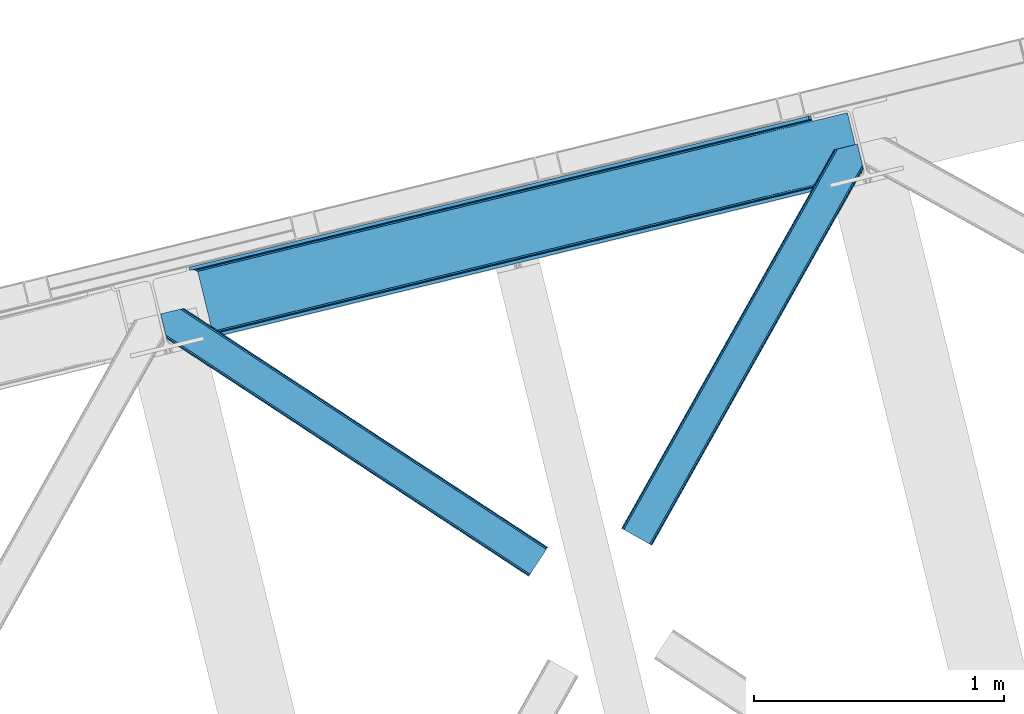
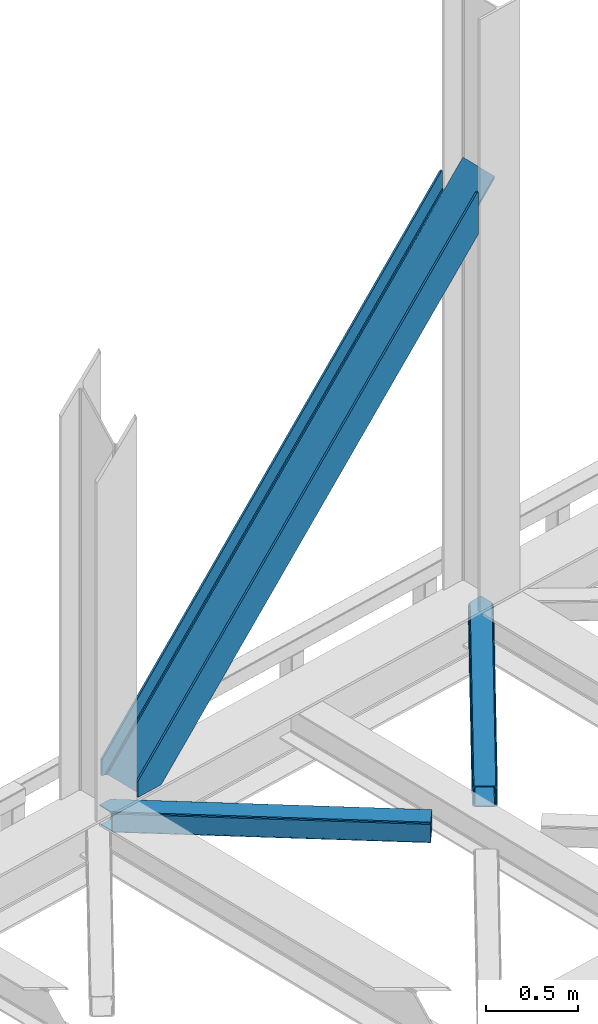
# One storey, part 81 of 92: 3 members.
"""IFC4 building model written with IfcOpenShell, lengths in millimetres."""

from ifc_helpers import new_model, entity, si_unit, converted_unit, derived_unit, direction, frame, origin, place, context, subcontext, project, spatial, triangles, polygons, type_object, element, save


model = new_model("IFC4")

# Units and contexts
model_context = context("Model", 3, precision=0.01, world=origin(), true_north=direction((6.12303176911189e-17, 1.0)))
plan_context = context("Plan", 3, precision=0.01, world=origin(), true_north=direction((6.12303176911189e-17, 1.0)))
body_context = subcontext(model_context, "Body", "Model", "MODEL_VIEW")
ifc_project = project(units=[si_unit("LENGTHUNIT", "METRE", prefix="MILLI"), si_unit("AREAUNIT", "SQUARE_METRE"), si_unit("VOLUMEUNIT", "CUBIC_METRE"), converted_unit("PLANEANGLEUNIT", "DEGREE", entity("IfcRatioMeasure", 0.0174532925199433), si_unit("PLANEANGLEUNIT", "RADIAN"), dimensions=[0, 0, 0, 0, 0, 0, 0]), si_unit("MASSUNIT", "GRAM", prefix="KILO"), derived_unit("MASSDENSITYUNIT", [(si_unit("MASSUNIT", "GRAM", prefix="KILO"), 1), (si_unit("LENGTHUNIT", "METRE"), -3)]), derived_unit("MOMENTOFINERTIAUNIT", [(si_unit("LENGTHUNIT", "METRE"), 4)]), si_unit("TIMEUNIT", "SECOND"), si_unit("FREQUENCYUNIT", "HERTZ"), si_unit("THERMODYNAMICTEMPERATUREUNIT", "DEGREE_CELSIUS"), derived_unit("THERMALTRANSMITTANCEUNIT", [(si_unit("MASSUNIT", "GRAM", prefix="KILO"), 1), (si_unit("THERMODYNAMICTEMPERATUREUNIT", "KELVIN"), -1), (si_unit("TIMEUNIT", "SECOND"), -3)]), derived_unit("VOLUMETRICFLOWRATEUNIT", [(si_unit("LENGTHUNIT", "METRE"), 3), (si_unit("TIMEUNIT", "SECOND"), -1)]), derived_unit("MASSFLOWRATEUNIT", [(si_unit("MASSUNIT", "GRAM", prefix="KILO"), 1), (si_unit("TIMEUNIT", "SECOND"), -1)]), derived_unit("ROTATIONALFREQUENCYUNIT", [(si_unit("TIMEUNIT", "SECOND"), -1)]), si_unit("ELECTRICCURRENTUNIT", "AMPERE"), si_unit("ELECTRICVOLTAGEUNIT", "VOLT"), si_unit("POWERUNIT", "WATT"), si_unit("FORCEUNIT", "NEWTON", prefix="KILO"), si_unit("ILLUMINANCEUNIT", "LUX"), si_unit("LUMINOUSFLUXUNIT", "LUMEN"), si_unit("LUMINOUSINTENSITYUNIT", "CANDELA"), derived_unit("USERDEFINED", [(si_unit("MASSUNIT", "GRAM", prefix="KILO"), -1), (si_unit("LENGTHUNIT", "METRE"), -2), (si_unit("TIMEUNIT", "SECOND"), 3), (si_unit("LUMINOUSFLUXUNIT", "LUMEN"), 1)]), derived_unit("LINEARVELOCITYUNIT", [(si_unit("LENGTHUNIT", "METRE"), 1), (si_unit("TIMEUNIT", "SECOND"), -1)]), si_unit("PRESSUREUNIT", "PASCAL"), derived_unit("USERDEFINED", [(si_unit("LENGTHUNIT", "METRE"), -2), (si_unit("MASSUNIT", "GRAM", prefix="KILO"), 1), (si_unit("TIMEUNIT", "SECOND"), -2)]), derived_unit("LINEARFORCEUNIT", [(si_unit("MASSUNIT", "GRAM", prefix="KILO"), 1), (si_unit("LENGTHUNIT", "METRE"), 1), (si_unit("TIMEUNIT", "SECOND"), -2), (si_unit("LENGTHUNIT", "METRE"), -1)]), derived_unit("PLANARFORCEUNIT", [(si_unit("MASSUNIT", "GRAM", prefix="KILO"), 1), (si_unit("LENGTHUNIT", "METRE"), 1), (si_unit("TIMEUNIT", "SECOND"), -2), (si_unit("LENGTHUNIT", "METRE"), -2)])], contexts=[model_context, plan_context])

# Site, building, storey
site_placement = place(None, origin())
site = spatial("IfcSite", under=ifc_project, at=site_placement, CompositionType="ELEMENT")
building_placement = place(site_placement, origin())
building = spatial("IfcBuilding", under=site, at=building_placement, CompositionType="ELEMENT")
storey_placement = place(building_placement, frame((0.0, 0.0, 15900.0)))
storey = spatial("IfcBuildingStorey", under=building, at=storey_placement, Name="05", CompositionType="ELEMENT", Elevation=15900.0)

# Members
member_type_1 = type_object("IfcMemberType", PredefinedType="BRACE")
member_1_placement = place(storey_placement, frame((-8823.81, 18506.66, 3695.0)))
element("IfcMember", 1, at=member_1_placement, inside=storey, type_object=member_type_1, ObjectType="Steel Vertical Brace", PredefinedType="BRACE", context=body_context, shape_type="Tessellation", body=[
    polygons([(3.07873920987602, 273.977680396013, 8.22979018266778e-11), (3.07873920888086, 273.977680395771, 106.65765827966), (8.66293703438714e-12, 286.607857151607, 106.65765827966), (1.94699509847851e-09, 286.607857152077, 8.22979018266778e-11), (2479.77214765689, 877.697901605217, 2779.57626168554), (2490.25200805125, 880.252478451081, 2781.6827939859), (2487.17326884237, 892.882655206916, 2781.6827939859), (2476.69340844802, 890.328078361052, 2779.57626168554), (2487.17326884247, 892.882655206941, 2501.09970740511), (169.685130105906, 327.970402848239, 2.16573425859679e-11), (8.63541989623741, 275.332180101836, 7.36349647922907e-11), (430.558974103208, 378.180510303083, 455.352008209132), (868.141546816823, 484.845891934476, 927.60367857852), (1305.72411953044, 591.511273565869, 1399.85534894791), (1743.30669224404, 698.17665519726, 1872.1070193173), (2180.88926495767, 804.842036828657, 2344.35868968668), (2490.25200805127, 880.252478451088, 2678.23184023292), (2490.25200805127, 880.252478451088, 2613.75429495), (2490.25200805132, 880.252478451101, 2501.09970740512), (2490.57649968366, 878.921288507687, 2668.25114832037), (2491.5005736714, 875.130380279116, 2659.78992627632), (2492.62026898089, 870.536957869669, 2654.86848791613), (2492.62026898092, 870.536957869678, 2637.1176472667), (2491.50057367143, 875.130380279123, 2632.1962089066), (2490.57649968368, 878.921288507693, 2623.73498686254), (37.0644416316784, 263.734998293174, 6.064055924071e-11), (33.5935732408485, 269.978935024565, 6.064055924071e-11), (26.9720355143378, 274.375474904885, 6.064055924071e-11), (18.2078975466542, 276.255284592099, 6.49720277579036e-11), (172.76386931478, 315.340226092406, 3.89832166547421e-11), (68.3795180485893, 289.895436106586, 5.63090907235164e-11), (59.4560236630099, 286.30995172954, 5.63090907235164e-11), (52.5400336707846, 280.607944959612, 5.63090907235164e-11), (48.6844448546242, 273.657494638702, 6.064055924071e-11), (48.4762356607877, 266.516743822171, 6.064055924071e-11), (103.656715327513, 40.1451142753133, 5.63090907235164e-11), (107.127583718358, 33.9011775439208, 6.064055924071e-11), (113.74912144486, 29.5046376635999, 5.63090907235164e-11), (122.513259412552, 27.6248279763929, 5.63090907235164e-11), (132.085737062963, 28.5479324666472, 5.63090907235164e-11), (236.470088329151, 53.9927224524679, 3.89832166547421e-11), (239.548827538027, 41.3625456966359, 3.89832166547421e-11), (69.8636974326473, 1.25612586998614e-10, 6.49720277579036e-11), (66.7849582256658, 12.6301767564212, 6.49720277579036e-11), (72.3416389106086, 13.9846764618998, 6.49720277579036e-11), (81.2651332961956, 17.5701608389472, 6.49720277579036e-11), (88.1811232884155, 23.272167608873, 6.064055924071e-11), (92.0367121045813, 30.2226179297901, 6.064055924071e-11), (92.244921298395, 37.3633687463099, 6.49720277579036e-11), (2222.97764830494, 815.101525555878, 2325.30413557918), (1786.65153917481, 708.742420216081, 1854.40847676752), (1350.32543004469, 602.383314876289, 1383.51281795587), (913.999320914564, 496.024209536497, 912.617159144216), (477.673211784457, 389.665104196709, 441.721500332565), (904.938963351569, 482.378592516732, 924.094449451942), (905.606971778055, 475.451429015364, 925.040088653782), (469.280862647932, 369.092323675568, 454.144429842122), (468.61285422145, 376.019487176942, 453.198790640286), (1341.2650724817, 588.73769785653, 1394.99010826359), (1341.93308090818, 581.810534355156, 1395.93574746543), (1777.59118161182, 695.096803196323, 1865.88576707524), (1778.2591900383, 688.169639694948, 1866.83140627709), (2213.91729074194, 801.455908536115, 2336.78142588689), (2214.58529916843, 794.528745034745, 2337.72706508874), (906.299295496529, 488.720797624748, 921.401496842631), (469.973186366417, 382.361692284952, 450.505838030984), (1342.62540462665, 595.079902964541, 1392.29715565429), (1778.95151375678, 701.439008304335, 1863.19281446594), (2215.2776228869, 807.798113644125, 2334.08847327759), (909.480869975318, 493.512501103935, 917.37120844897), (473.154760845203, 387.153395764143, 446.475549637314), (1345.80697910544, 599.871606443729, 1388.26686726062), (1782.13308823556, 706.230711783521, 1859.16252607227), (2218.45919736569, 812.589817123318, 2330.05818488392), (2633.7716358822, 903.743176316763, 2789.55036821242), (2635.38992615553, 897.104324888126, 2791.87149493081), (2633.49531741129, 904.87674135324, 2789.15404241364), (873.308981020911, 484.69522048025, 922.84962927377), (435.726408307295, 378.029838848855, 450.597958904382), (1310.89155373453, 591.36060211164, 1395.10129964316), (1748.47412644814, 698.025983743035, 1867.35297001255), (2186.05669916176, 804.691365374426, 2339.60464038193), (878.338703475162, 481.905107502299, 918.8193408801), (440.756130761546, 375.239725870908, 446.567670510716), (1315.92127618878, 588.570489133689, 1391.07101124949), (1753.50384890239, 695.235870765082, 1863.32268161888), (2191.08642161601, 801.901252396475, 2335.57435198827), (882.464984530468, 476.900322409075, 916.126388270803), (444.882411816845, 370.23494077768, 443.874717901414), (1320.04755724407, 583.565704040466, 1388.37805864019), (1757.63012995769, 690.231085671857, 1860.62972900958), (2195.21270267131, 796.89646730325, 2332.88139937898), (885.059635300978, 470.442798362535, 915.180749068945), (447.477062587366, 363.777416731142, 442.92907869957), (1322.64220801459, 577.108179993928, 1387.43241943833), (1760.22478072821, 683.773561625319, 1859.68408980773), (2197.80735344184, 790.438943256716, 2331.93576017711), (2635.38992615552, 897.104324888122, 2804.1874305464), (2632.79527538494, 903.561848934653, 2805.13306974834), (2632.17672481338, 904.555320457061, 2805.48182008997), (2633.49531741129, 904.876741353238, 2804.18743054672), (2690.5704058222, 670.73269534126, 2804.18743054641), (2692.46501456602, 662.960278876044, 2804.18743054645), (2692.46501456602, 662.960278876044, 2789.15404241398), (2692.18869609554, 664.093843912616, 2789.55036821231), (2690.5704058222, 670.732695341257, 2791.8714949308), (69.8636974321264, -2.16573425859679e-12, 106.65765827966), (66.7849582232532, 12.6301767558321, 106.65765827966), (2546.55710588013, 603.720221209447, 2779.57626168555), (2543.47836667126, 616.350397965279, 2779.57626168555), (2553.95822706562, 618.904974811143, 2781.6827939859), (2553.95822706564, 618.904974811149, 2678.23184023292), (2244.59548397204, 543.494533188718, 2344.35868968668), (1807.01291125842, 436.829151557321, 1872.1070193173), (1369.43033854481, 330.163769925931, 1399.85534894791), (931.847765831195, 223.498388294538, 927.60367857852), (494.26519311758, 116.833006663145, 455.352008209132), (2557.03696627459, 606.274798055334, 2501.09970740512), (2557.03696627449, 606.274798055313, 2781.6827939859), (2553.9582270657, 618.904974811162, 2501.09970740512), (2553.95822706565, 618.904974811149, 2613.75429495), (2553.63373543322, 620.236164754546, 2623.73498686254), (2552.70966144549, 624.027072983117, 2632.1962089066), (2551.58996613549, 628.620495392442, 2637.1176472667), (2551.58996613555, 628.620495392438, 2654.86848791611), (2552.70966144548, 624.027072983114, 2659.78992627632), (2553.6337354332, 620.236164754539, 2668.25114832037), (541.379430798829, 128.317600556771, 441.721500332565), (977.705539928937, 234.676705896559, 912.617159144216), (1414.03164905906, 341.035811236351, 1383.51281795587), (1850.35775818918, 447.394916576147, 1854.40847676752), (2286.68386731931, 553.754021915942, 2325.30413557918), (2269.76577883516, 568.157115487885, 2337.72706508874), (1833.43966970503, 461.798010148093, 1866.83140627708), (1397.11356057491, 355.438904808298, 1395.93574746542), (960.787451444785, 249.079799468504, 925.040088653773), (524.46134231466, 142.72069412871, 454.144429842118), (972.538105724858, 234.827377350792, 917.37120844897), (536.211996594743, 128.468272010997, 446.475549637314), (1408.86421485498, 341.186482690582, 1388.26686726062), (1845.19032398511, 447.545588030378, 1859.16252607227), (2281.51643311522, 553.904693370168, 2330.05818488392), (967.508383270606, 237.61749032874, 921.401496842631), (531.182274140491, 131.25838498895, 450.505838030984), (1403.83449240073, 343.976595668535, 1392.29715565429), (1840.16060153086, 450.335701008331, 1863.19281446594), (2276.48671066098, 556.694806348128, 2334.08847327759), (963.382102215302, 242.622275421964, 924.094449451942), (527.055993085183, 136.263170082167, 453.198790640286), (1399.70821134543, 348.981380761758, 1394.99010826359), (1836.03432047555, 455.340486101554, 1865.88576707524), (2272.36042960567, 561.699591441347, 2336.78142588689), (502.657542254084, 137.40578718428, 442.929078699574), (940.240114967703, 244.071168815673, 915.180749068945), (1377.82268768133, 350.73655044707, 1387.43241943833), (1815.40526039496, 457.401932078467, 1859.68408980771), (2252.98783310858, 564.06731370986, 2331.93576017708), (940.9081233942, 237.144005314307, 916.126388270803), (503.325550680576, 130.47862368291, 443.87471790141), (1378.49069610781, 343.809386945698, 1388.37805864019), (1816.07326882142, 450.474768577091, 1860.62972900958), (2253.65584153503, 557.14015020849, 2332.88139937899), (2691.23841424869, 663.805531839872, 2805.13306974833), (939.547791249238, 230.801800206293, 918.8193408801), (501.965218535623, 124.1364185749, 446.567670510716), (1377.13036396285, 337.46718183769, 1391.07101124949), (1814.71293667646, 444.132563469083, 1863.32268161888), (2252.29550939008, 550.797945100476, 2335.57435198827), (936.36621677045, 226.010096727104, 922.84962927377), (498.783644056835, 119.344715095711, 450.597958904382), (1373.94878948407, 332.675478358499, 1395.10129964316), (1811.53136219768, 439.34085998989, 1867.35297001255), (2249.1139349113, 546.006241621281, 2339.60464038193), (2691.14642196792, 662.638857979852, 2805.48182009003)], [[[1, 2, 3, 4]], [[5, 6, 7, 8]], [[3, 2, 5, 8]], [[4, 3, 8, 7, 9, 10]], [[2, 1, 11, 12, 13, 14, 15, 16, 17, 6, 5]], [[18, 19, 9, 7, 6, 17, 20, 21, 22, 23, 24, 25]], [[26, 27, 28, 29, 11, 1, 4, 10, 30, 31, 32, 33, 34, 35, 36, 37, 38, 39, 40, 41, 42, 43, 44, 45, 46, 47, 48, 49]], [[10, 9, 19, 30]], [[30, 19, 18, 50, 51, 52, 53, 54, 31]], [[55, 56, 57, 58]], [[59, 60, 56, 55]], [[61, 62, 60, 59]], [[63, 64, 62, 61]], [[65, 55, 58, 66]], [[67, 59, 55, 65]], [[68, 61, 59, 67]], [[69, 63, 61, 68]], [[70, 65, 66, 71]], [[72, 67, 65, 70]], [[73, 68, 67, 72]], [[74, 69, 68, 73]], [[53, 70, 71, 54]], [[52, 72, 70, 53]], [[51, 73, 72, 52]], [[50, 74, 73, 51]], [[64, 75, 76]], [[35, 34, 58, 57]], [[34, 33, 66, 58]], [[33, 32, 71, 66]], [[32, 31, 54, 71]], [[18, 25, 74, 50]], [[25, 24, 69, 74]], [[75, 23, 77]], [[63, 24, 23]], [[24, 63, 69]], [[23, 75, 63]], [[75, 64, 63]], [[78, 13, 12, 79]], [[80, 14, 13, 78]], [[81, 15, 14, 80]], [[82, 16, 15, 81]], [[83, 78, 79, 84]], [[85, 80, 78, 83]], [[86, 81, 80, 85]], [[87, 82, 81, 86]], [[88, 83, 84, 89]], [[90, 85, 83, 88]], [[91, 86, 85, 90]], [[92, 87, 86, 91]], [[93, 88, 89, 94]], [[95, 90, 88, 93]], [[96, 91, 90, 95]], [[97, 92, 91, 96]], [[98, 99, 92, 97]], [[21, 20, 82, 87]], [[20, 17, 16, 82]], [[11, 29, 79, 12]], [[29, 28, 84, 79]], [[28, 27, 89, 84]], [[27, 26, 94, 89]], [[22, 99, 100]], [[87, 22, 21]], [[92, 22, 87]], [[22, 92, 99]], [[23, 22, 100, 101, 77]], [[98, 101, 100, 99]], [[101, 98, 102, 103, 104, 105, 106, 76, 75, 77]], [[43, 107, 108, 44]], [[108, 107, 109, 110]], [[44, 108, 110, 111, 112, 113, 114, 115, 116, 117, 45]], [[107, 43, 42, 118, 119, 109]], [[109, 119, 111, 110]], [[112, 111, 119, 118, 120, 121, 122, 123, 124, 125, 126, 127]], [[41, 120, 118, 42]], [[40, 128, 129, 130, 131, 132, 121, 120, 41]], [[35, 57, 56, 60, 62, 64, 76, 106, 133, 134, 135, 136, 137, 36]], [[138, 129, 128, 139]], [[140, 130, 129, 138]], [[141, 131, 130, 140]], [[142, 132, 131, 141]], [[143, 138, 139, 144]], [[145, 140, 138, 143]], [[146, 141, 140, 145]], [[147, 142, 141, 146]], [[148, 143, 144, 149]], [[150, 145, 143, 148]], [[151, 146, 145, 150]], [[152, 147, 146, 151]], [[136, 148, 149, 137]], [[135, 150, 148, 136]], [[134, 151, 150, 135]], [[133, 152, 151, 134]], [[133, 105, 152]], [[123, 122, 142, 147]], [[122, 121, 132, 142]], [[40, 39, 139, 128]], [[39, 38, 144, 139]], [[38, 37, 149, 144]], [[37, 36, 137, 149]], [[124, 105, 104]], [[147, 124, 123]], [[152, 124, 147]], [[124, 152, 105]], [[105, 133, 106]], [[98, 97, 96, 95, 93, 94, 26, 49, 153, 154, 155, 156, 157, 102]], [[158, 154, 153, 159]], [[160, 155, 154, 158]], [[161, 156, 155, 160]], [[162, 157, 156, 161]], [[163, 102, 157, 162]], [[164, 158, 159, 165]], [[166, 160, 158, 164]], [[167, 161, 160, 166]], [[168, 162, 161, 167]], [[169, 164, 165, 170]], [[171, 166, 164, 169]], [[172, 167, 166, 171]], [[173, 168, 167, 172]], [[116, 169, 170, 117]], [[115, 171, 169, 116]], [[114, 172, 171, 115]], [[113, 173, 172, 114]], [[112, 127, 173, 113]], [[127, 126, 168, 173]], [[162, 125, 174, 163]], [[49, 48, 159, 153]], [[48, 47, 165, 159]], [[47, 46, 170, 165]], [[46, 45, 117, 170]], [[168, 125, 162]], [[125, 168, 126]], [[104, 103, 174, 125, 124]], [[174, 103, 102, 163]]], closed=True),
])
member_type_2 = type_object("IfcMemberType", PredefinedType="BRACE")
member_2_placement = place(storey_placement, frame((-8936.9, 17557.16, 3510.0)))
element("IfcMember", 2, at=member_2_placement, inside=storey, type_object=member_type_2, ObjectType="Steel Horizontal Brace", PredefinedType="BRACE", context=body_context, shape_type="Tessellation", body=[
    triangles([(1548.83743743897, 117.035879516603, 122.500662231447), (1548.83743743897, 117.035879516603, 17.5000946044929), (93.3082580566406, 1072.51941833496, 122.500662231447), (93.3082580566406, 1072.51941833496, 17.5000946044929), (1539.23453521729, 102.405377197265, 139.999594116212), (1542.91047363281, 108.005035400391, 138.667117309571), (78.9527389526374, 1069.01963195801, 138.667117309571), (70.0556076049816, 1066.85115966797, 139.999594116212), (1546.02365570068, 112.750094604493, 134.874325561526), (86.4987899780281, 1070.85905456543, 134.874325561526), (1548.10841217041, 115.921994018554, 129.197927856447), (91.5368545532237, 1072.08804931641, 129.197927856447), (18.1488922119152, 975.320700073244, 139.999594116212), (0.0, 1049.77429504395, 139.999594116212), (1481.61595916748, 14.6293395996108, 139.999594116212), (1472.01247558594, 0.0, 122.500662231447), (1472.74150085449, 1.11272277832177, 129.197927856447), (24.2235214233406, 950.398965454104, 122.500662231447), (23.761340332032, 952.295361328124, 129.197927856447), (1474.82218780518, 4.28462219238281, 134.874325561526), (22.4445602416999, 957.698519897462, 134.874325561526), (1477.94002075195, 9.03084411621239, 138.667117309571), (20.4737503051765, 965.782910156249, 138.667117309571), (1472.01247558594, 0.0, 17.5000946044929), (24.2235214233406, 950.398965454104, 17.5000946044929), (1546.02365570068, 112.750094604493, 5.12526855468968), (1542.91047363281, 108.005035400391, 1.33247680664135), (168.079856872559, 1010.51157531739, 1.33247680664135), (166.329963684082, 1017.69020690918, 4.52065429687718), (1548.10841217041, 115.921994018554, 10.8028289794929), (165.5428024292, 1018.81804504395, 5.02062377929906), (164.75099029541, 1019.94588317871, 5.52059326172093), (91.5368545532237, 1072.08804931641, 10.8028289794929), (87.0045730590828, 1070.98230285645, 5.52059326172093), (1539.23453521729, 102.405377197265, 0.0), (170.404133605958, 1000.97494812012, 0.0), (197.80304260254, 888.574832153321, 0.0), (163.159226989746, 880.129998779299, 0.0), (1481.61595916748, 14.6293395996108, 0.0), (196.831590270996, 888.337637329103, 5.52059326172093), (146.210261535645, 875.997692871093, 5.52059326172093), (154.262095642091, 877.960363769533, 1.33247680664135), (197.80304260254, 888.574832153321, 4.52065429687718), (23.9723739624023, 951.429135131835, 12.5201660156272), (25.5711135864258, 951.450064086916, 10.9621215820334), (1472.74150085449, 1.11272277832177, 10.8028289794929), (1474.82218780518, 4.28462219238281, 5.12526855468968), (31.1539123535167, 951.523315429688, 5.52059326172093), (1477.94002075195, 9.03084411621239, 1.33247680664135), (6.80016632080151, 1051.43233337402, 5.52059326172093), (22.4835113525387, 980.848269653321, 6.99957275390625), (23.177655029298, 972.383670043946, 8.3320495605476), (5.36304473876953, 1051.08235473633, 6.99957275390625), (20.1470260620117, 967.122363281251, 12.5201660156272), (60.7521057128906, 1064.58385620117, 6.99957275390625), (1535.39523468018, 96.5545715332046, 6.99957275390625), (1485.45525970459, 20.4813079833984, 6.99957275390625), (1481.77932128906, 14.8816497802727, 8.3320495605476), (1478.66613922119, 10.1365905761741, 12.1260040283232), (21.3312561035164, 962.264520263674, 17.8035644531265), (1475.85235748291, 5.85196838379125, 24.4996673583992), (1476.58138275146, 6.96469116210938, 17.8035644531265), (21.7934371948249, 960.366961669923, 24.4996673583992), (1539.0711730957, 102.153067016603, 8.3320495605476), (69.6533065795902, 1066.75349121094, 8.3320495605476), (1542.18435516357, 106.899288940429, 12.1260040283232), (77.1952880859371, 1068.59175109863, 12.1260040283232), (1544.2644607544, 110.070025634766, 17.8035644531265), (82.2380035400402, 1069.82074584961, 17.8035644531265), (1544.99813690186, 111.183911132812, 24.4996673583992), (84.0047561645515, 1070.25095214844, 24.4996673583992), (1544.99813690186, 111.183911132812, 115.501089477541), (84.0047561645515, 1070.25095214844, 115.501089477541), (77.1952880859371, 1068.59175109863, 127.87475280762), (69.6533065795902, 1066.75349121094, 131.667544555665), (82.2380035400402, 1069.82074584961, 122.196029663086), (60.7521057128906, 1064.58385620117, 133.000021362306), (0.0, 1049.77429504395, 133.000021362306), (1544.2644607544, 110.070025634766, 122.196029663086), (1542.18435516357, 106.899288940429, 127.87475280762), (1539.0711730957, 102.153067016603, 131.667544555665), (1535.39523468018, 96.5545715332046, 133.000021362306), (1478.66613922119, 10.1365905761741, 127.87475280762), (1485.45525970459, 20.4813079833984, 133.000021362306), (1481.77932128906, 14.8816497802727, 131.667544555665), (1475.85235748291, 5.85196838379125, 115.501089477541), (1476.58138275146, 6.96469116210938, 122.196029663086), (21.3312561035164, 962.264520263674, 122.196029663086), (20.0144760131843, 967.666516113281, 127.87475280762), (21.7934371948249, 960.366961669923, 115.501089477541), (18.0436660766609, 975.752069091799, 131.667544555665), (15.7188079833995, 985.288696289063, 133.000021362306)], [[1, 2, 3], [4, 3, 2], [5, 6, 7], [7, 8, 5], [6, 9, 10], [10, 7, 6], [9, 11, 12], [12, 10, 9], [11, 1, 3], [3, 12, 11], [8, 13, 5], [8, 14, 13], [15, 5, 13], [16, 17, 18], [19, 18, 17], [17, 20, 19], [21, 19, 20], [20, 22, 21], [23, 21, 22], [22, 15, 23], [13, 23, 15], [24, 16, 25], [18, 25, 16], [26, 27, 28], [28, 29, 26], [30, 26, 31], [30, 32, 33], [34, 33, 32], [29, 31, 26], [27, 35, 36], [36, 28, 27], [2, 30, 4], [33, 4, 30], [37, 36, 35], [38, 37, 39], [35, 39, 37], [38, 40, 37], [41, 38, 42], [37, 40, 43], [38, 41, 40], [29, 36, 43], [36, 29, 28], [37, 43, 36], [24, 44, 45], [24, 25, 44], [46, 45, 41], [41, 47, 46], [45, 48, 41], [47, 41, 42], [39, 49, 38], [42, 38, 49], [42, 49, 47], [45, 46, 24], [48, 34, 32], [34, 48, 50], [32, 41, 48], [40, 41, 32], [48, 51, 50], [51, 48, 52], [53, 50, 51], [54, 52, 48], [45, 44, 54], [45, 54, 48], [55, 51, 56], [55, 53, 51], [57, 56, 51], [58, 52, 54], [59, 54, 60], [61, 62, 63], [60, 63, 62], [60, 62, 59], [54, 59, 58], [58, 57, 52], [51, 52, 57], [56, 64, 65], [65, 55, 56], [64, 66, 67], [67, 65, 64], [66, 68, 69], [69, 67, 66], [68, 70, 71], [71, 69, 68], [70, 72, 73], [73, 71, 70], [74, 75, 7], [10, 74, 7], [76, 10, 12], [76, 3, 73], [10, 76, 74], [3, 76, 12], [75, 8, 7], [14, 77, 78], [14, 8, 77], [75, 77, 8], [3, 71, 73], [34, 67, 69], [69, 71, 4], [4, 71, 3], [69, 33, 34], [33, 69, 4], [50, 55, 34], [55, 65, 34], [65, 67, 34], [50, 53, 55], [72, 79, 73], [76, 73, 79], [79, 80, 76], [74, 76, 80], [80, 81, 74], [75, 74, 81], [81, 82, 75], [77, 75, 82], [11, 80, 79], [72, 2, 1], [11, 79, 1], [11, 9, 80], [79, 72, 1], [80, 9, 6], [82, 5, 15], [5, 81, 6], [81, 5, 82], [81, 80, 6], [30, 66, 26], [70, 2, 72], [2, 68, 30], [68, 2, 70], [30, 68, 66], [35, 56, 39], [27, 26, 66], [66, 64, 27], [64, 56, 35], [35, 27, 64], [83, 22, 20], [15, 84, 82], [15, 85, 84], [85, 15, 22], [83, 85, 22], [86, 16, 24], [17, 87, 83], [20, 17, 83], [87, 17, 16], [86, 87, 16], [49, 59, 47], [39, 56, 57], [57, 58, 39], [58, 59, 49], [49, 39, 58], [46, 47, 59], [24, 61, 86], [62, 24, 46], [24, 62, 61], [62, 46, 59], [88, 21, 89], [90, 63, 18], [19, 88, 18], [88, 19, 21], [88, 90, 18], [63, 25, 18], [60, 54, 44], [44, 25, 60], [63, 60, 25], [91, 23, 13], [14, 92, 13], [78, 92, 14], [91, 89, 23], [23, 89, 21], [92, 91, 13], [92, 77, 82], [77, 92, 78], [82, 84, 92], [84, 85, 91], [91, 92, 84], [85, 83, 89], [89, 91, 85], [83, 87, 88], [88, 89, 83], [87, 86, 90], [90, 88, 87], [86, 61, 90], [63, 90, 61]]),
])
member_type_3 = type_object("IfcMemberType", PredefinedType="BRACE")
member_3_placement = place(storey_placement, frame((-7093.95, 17681.05, 3510.0)))
element("IfcMember", 3, at=member_3_placement, inside=storey, type_object=member_type_3, ObjectType="Steel Horizontal Brace", PredefinedType="BRACE", context=body_context, shape_type="Tessellation", body=[
    triangles([(963.930697631836, 1521.10947875976, 138.667117309571), (961.605839538574, 1530.64726867676, 139.999594116212), (106.81092224121, 8.56924438476563, 139.999594116212), (112.646612548828, 5.28921203613208, 138.667117309571), (965.901507568359, 1513.02392578125, 134.874325561526), (117.598635864258, 2.50914916992042, 134.874325561526), (967.218287658691, 1507.62192993164, 129.197927856447), (120.904829406738, 0.651123046875, 129.197927856447), (967.681050109863, 1505.72553405762, 122.500662231447), (122.068711853027, 0.0, 122.500662231447), (967.681050109863, 1505.72553405762, 17.5000946044929), (122.068711853027, 0.0, 17.5000946044929), (15.2577896118164, 59.9835479736321, 139.999594116212), (873.405990600586, 1588.02516174316, 139.999594116212), (943.45694732666, 1605.10086364746, 139.999594116212), (851.920092773437, 1582.787109375, 129.197927856447), (850.14868927002, 1582.35574035644, 122.500662231447), (1.15981292724609, 67.8993438720681, 129.197927856447), (0.0, 68.5527923583977, 122.500662231447), (856.962808227539, 1584.0172668457, 134.874325561526), (4.47007598876917, 66.04248046875, 134.874325561526), (864.504208374024, 1585.8555267334, 138.667117309571), (9.41802978515625, 63.2624176025383, 138.667117309571), (850.14868927002, 1582.35574035644, 17.5000946044929), (0.0, 68.5527923583977, 17.5000946044929), (1.15981292724609, 67.8993438720681, 10.8028289794929), (851.920092773437, 1582.787109375, 10.8028289794929), (810.913293457031, 1502.80361938477, 5.52059326172093), (4.47007598876917, 66.04248046875, 5.12526855468968), (810.772023010254, 1501.75252075195, 5.13573303222802), (856.451792907715, 1583.89285583496, 5.52059326172093), (810.640054321289, 1500.7432800293, 4.7659881591826), (810.549362182617, 1500.07355346679, 4.52065429687718), (9.41802978515625, 63.2624176025383, 1.33247680664135), (812.299255371094, 1492.894921875, 1.33247680664135), (814.624113464355, 1483.35829467773, 0.0), (15.2577896118164, 59.9835479736321, 0.0), (842.022441101074, 1370.95817871093, 0.0), (106.81092224121, 8.56924438476563, 0.0), (876.666256713867, 1379.40301208496, 0.0), (893.620454406738, 1383.53648071289, 5.52059326172093), (885.56803894043, 1381.57264709473, 1.33247680664135), (842.993893432617, 1371.19537353516, 5.52059326172093), (842.022441101074, 1370.95817871093, 4.52065429687718), (117.598635864258, 2.50914916992042, 5.12526855468968), (112.646612548828, 5.28921203613208, 1.33247680664135), (966.000920104981, 1506.03830566406, 10.9621215820334), (120.904829406738, 0.651123046875, 10.8028289794929), (967.429902648925, 1506.75570373535, 12.5201660156272), (961.010527038574, 1503.53380737305, 5.52059326172093), (936.65678100586, 1603.44282531738, 5.52059326172093), (963.604554748535, 1522.44893188476, 12.5201660156272), (958.492657470703, 1525.72547607422, 8.3320495605476), (955.213787841797, 1533.55988159179, 6.99957275390625), (938.093321228027, 1603.79280395508, 6.99957275390625), (21.3638122558596, 56.5558502197237, 6.99957275390625), (882.70484161377, 1590.29130249023, 6.99957275390625), (100.704899597168, 11.9957794189431, 6.99957275390625), (111.497264099121, 5.9380096435525, 12.1260040283232), (114.803457641601, 4.07998352050708, 17.8035644531265), (964.788784790039, 1517.59108886719, 17.8035644531265), (106.544659423828, 8.71690979003688, 8.3320495605476), (965.250965881348, 1515.69353027343, 24.4996673583992), (115.962689208985, 3.4265350341775, 24.4996673583992), (965.250965881348, 1515.69353027343, 115.501089477541), (115.962689208985, 3.4265350341775, 115.501089477541), (964.788784790039, 1517.59108886719, 122.196029663086), (963.472004699707, 1522.9930847168, 127.87475280762), (961.50061340332, 1531.07863769531, 131.667544555665), (959.176336669922, 1540.61526489258, 133.000021362306), (943.45694732666, 1605.10086364746, 133.000021362306), (114.803457641601, 4.07998352050708, 122.196029663086), (111.497264099121, 5.9380096435525, 127.87475280762), (106.544659423828, 8.71690979003688, 131.667544555665), (100.704899597168, 11.9957794189431, 133.000021362306), (21.3638122558596, 56.5558502197237, 133.000021362306), (882.70484161377, 1590.29130249023, 133.000021362306), (10.5714477539059, 62.6147827148416, 127.87475280762), (15.5240524291994, 59.8347198486299, 131.667544555665), (6.10137176513672, 65.1239318847656, 115.501089477541), (7.2652542114256, 64.4728088378906, 122.196029663086), (10.5714477539059, 62.6147827148416, 12.1260040283232), (15.5240524291994, 59.8347198486299, 8.3320495605476), (6.10137176513672, 65.1239318847656, 24.4996673583992), (7.2652542114256, 64.4728088378906, 17.8035644531265), (873.807710266113, 1588.12283020019, 131.667544555665), (866.261659240722, 1586.28340759277, 127.87475280762), (861.223594665527, 1585.05557556152, 122.196029663086), (859.45219116211, 1584.62420654297, 115.501089477541), (873.807710266113, 1588.12283020019, 8.3320495605476), (861.223594665527, 1585.05557556152, 17.8035644531265), (866.261659240722, 1586.28340759277, 12.1260040283232), (859.45219116211, 1584.62420654297, 24.4996673583992)], [[1, 2, 3], [3, 4, 1], [5, 1, 4], [4, 6, 5], [7, 5, 6], [6, 8, 7], [9, 7, 8], [8, 10, 9], [11, 9, 10], [10, 12, 11], [13, 2, 14], [13, 3, 2], [2, 15, 14], [16, 17, 18], [19, 18, 17], [20, 16, 21], [18, 21, 16], [22, 20, 23], [21, 23, 20], [14, 22, 13], [23, 13, 22], [17, 24, 19], [25, 19, 24], [26, 27, 28], [28, 29, 26], [28, 30, 29], [27, 31, 28], [29, 30, 32], [33, 34, 29], [33, 35, 34], [35, 36, 34], [37, 34, 36], [24, 27, 26], [26, 25, 24], [38, 37, 36], [39, 38, 40], [38, 39, 37], [40, 41, 42], [40, 38, 43], [40, 43, 41], [43, 38, 44], [36, 33, 44], [36, 35, 33], [44, 38, 36], [45, 46, 42], [47, 48, 41], [48, 45, 41], [12, 48, 47], [47, 49, 12], [49, 11, 12], [41, 50, 47], [42, 41, 45], [40, 42, 46], [46, 39, 40], [41, 28, 50], [41, 43, 28], [31, 50, 28], [51, 50, 31], [52, 50, 53], [49, 47, 52], [52, 47, 50], [54, 50, 51], [50, 54, 53], [51, 55, 54], [56, 54, 57], [56, 58, 54], [54, 55, 57], [59, 60, 61], [61, 52, 59], [62, 59, 52], [53, 54, 58], [58, 62, 53], [52, 53, 62], [63, 61, 60], [60, 64, 63], [65, 63, 66], [64, 66, 63], [61, 49, 52], [9, 11, 63], [11, 61, 63], [63, 65, 9], [11, 49, 61], [67, 9, 65], [7, 9, 67], [5, 67, 68], [67, 5, 7], [68, 1, 5], [69, 1, 68], [69, 70, 2], [69, 2, 1], [70, 15, 2], [70, 71, 15], [67, 65, 72], [66, 72, 65], [68, 67, 73], [72, 73, 67], [69, 68, 74], [73, 74, 68], [70, 69, 75], [74, 75, 69], [76, 70, 75], [70, 76, 77], [71, 70, 77], [8, 73, 72], [66, 12, 10], [8, 72, 10], [8, 6, 73], [72, 66, 10], [73, 6, 4], [75, 3, 13], [3, 74, 4], [74, 3, 75], [74, 73, 4], [48, 59, 45], [64, 12, 66], [12, 60, 48], [60, 12, 64], [48, 60, 59], [39, 58, 37], [46, 45, 59], [59, 62, 46], [62, 58, 39], [39, 46, 62], [78, 23, 21], [13, 76, 75], [13, 79, 76], [79, 13, 23], [78, 79, 23], [80, 19, 25], [18, 81, 78], [21, 18, 78], [81, 18, 19], [80, 81, 19], [34, 82, 29], [37, 58, 56], [56, 83, 37], [83, 82, 34], [34, 37, 83], [26, 29, 82], [25, 84, 80], [85, 25, 26], [25, 85, 84], [85, 26, 82], [22, 14, 86], [15, 77, 14], [77, 15, 71], [77, 86, 14], [87, 22, 86], [87, 20, 22], [20, 88, 16], [88, 20, 87], [17, 88, 89], [88, 17, 16], [57, 31, 90], [91, 92, 31], [92, 90, 31], [57, 51, 31], [51, 57, 55], [93, 91, 24], [27, 24, 91], [17, 93, 24], [93, 17, 89], [91, 31, 27], [91, 93, 85], [84, 85, 93], [92, 91, 82], [85, 82, 91], [90, 92, 83], [82, 83, 92], [57, 90, 56], [83, 56, 90], [93, 89, 84], [80, 84, 89], [86, 77, 76], [76, 79, 86], [87, 86, 79], [79, 78, 87], [88, 87, 78], [78, 81, 88], [89, 88, 81], [81, 80, 89]]),
])

save(model, "model.ifc")
